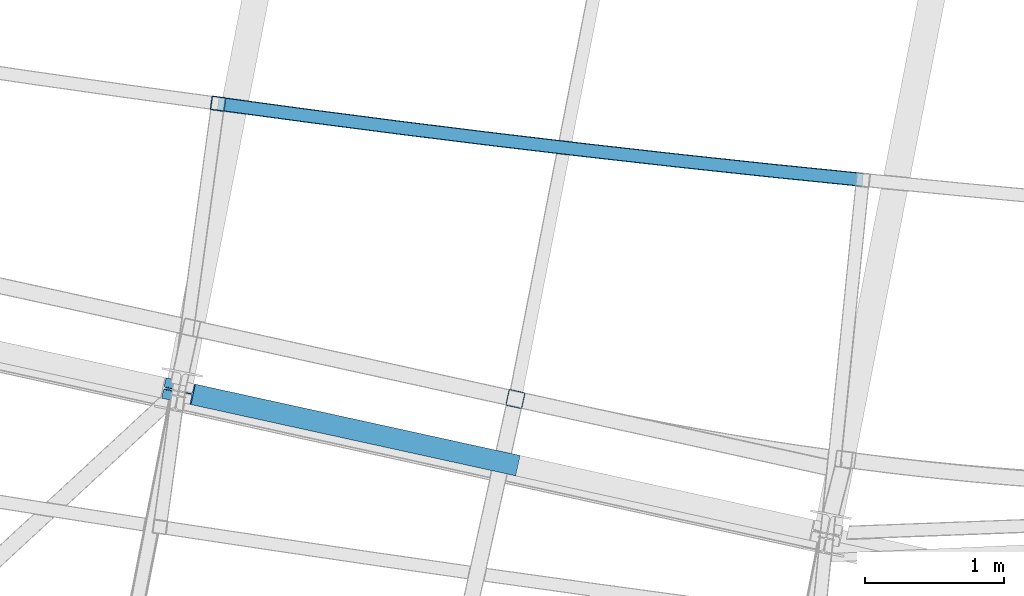
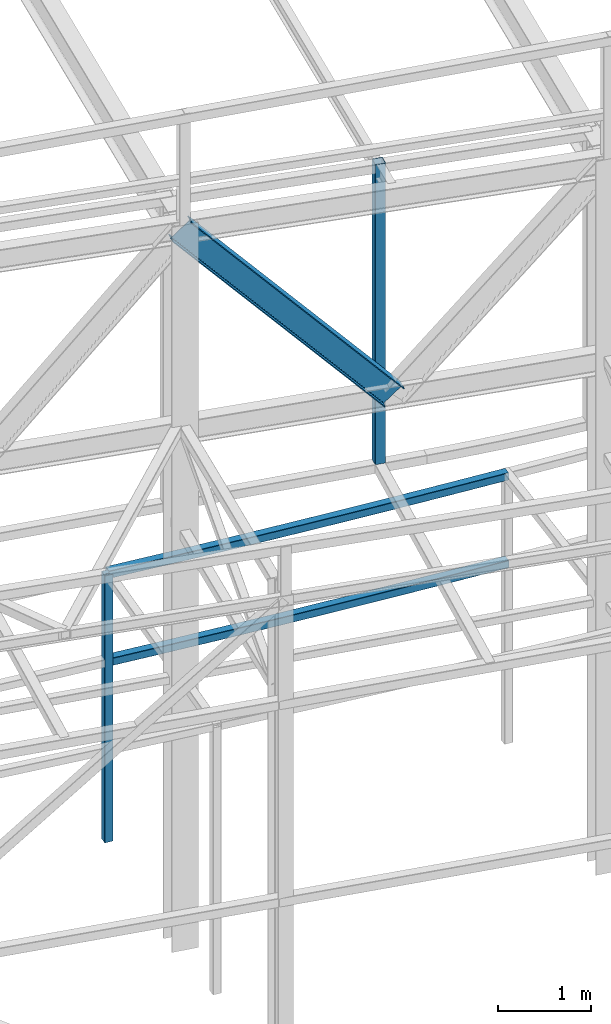
# One storey, part 49 of 215: 4 beams, 1 member, 5 elements without a shape of their own.
"""IFC2X3 building model written with IfcOpenShell, lengths in millimetres."""

import ifcopenshell
import ifcopenshell.guid

model = None  # the IFC model being written
_history = None  # IfcOwnerHistory: only IFC2X3 demands one
_inside = {}  # id of a spatial element -> (the spatial element, [elements in it])
_under = {}  # id of a project, library or spatial element -> (it, [spatial elements below it])
_declared = {}  # id of a project -> (the project, [libraries it declares])
_typed = {}  # id of a type object -> (the type object, [elements of that type])
_made_of = {}  # id of a material, layer set ... -> (it, [elements and type objects made of it])


def new_model(schema):
    """Start an empty IFC model of exactly this schema.

    Asked for "IFC4X3", IfcOpenShell would pick the latest addendum, in which some entities
    have other attributes; the version numbers below select the first issue.
    IFC2X3 requires an IfcOwnerHistory on every rooted entity: one is made here for all.
    """
    global model, _history
    if schema == "IFC4X3":
        model = ifcopenshell.file(schema_version=(4, 3, 0, 0))
    else:
        model = ifcopenshell.file(schema=schema)
    _inside.clear()
    _under.clear()
    _declared.clear()
    _typed.clear()
    _made_of.clear()
    _history = None
    if model.schema == "IFC2X3":
        org = make("IfcOrganization", Name="unknown")
        user = make(
            "IfcPersonAndOrganization",
            ThePerson=make("IfcPerson", FamilyName="unknown"),
            TheOrganization=org,
        )
        app = make(
            "IfcApplication",
            ApplicationDeveloper=org,
            Version="unknown",
            ApplicationFullName="unknown",
            ApplicationIdentifier="unknown",
        )
        _history = make(
            "IfcOwnerHistory",
            OwningUser=user,
            OwningApplication=app,
            ChangeAction="ADDED",
            CreationDate=0,
        )
    return model


def make(cls, **values):
    """One entity of the class cls with the attributes given. An attribute that is None is left unset."""
    return model.create_entity(
        cls, **{name: value for name, value in values.items() if value is not None}
    )


def entity(cls, *values):
    """Any entity or typed value of the class cls, its attributes in the order of the schema. None: left unset."""
    e = model.create_entity(cls)
    for i, value in enumerate(values):
        if value is not None:
            e[i] = value
    return e


def rooted(cls, **values):
    """An entity with a GlobalId (a new one), such as an element, a storey or a relation."""
    return make(cls, GlobalId=ifcopenshell.guid.new(), OwnerHistory=_history, **values)


def si_unit(unit_type, name, prefix=None):
    """IfcSIUnit, for example si_unit("LENGTHUNIT", "METRE", prefix="MILLI")."""
    return make("IfcSIUnit", UnitType=unit_type, Prefix=prefix, Name=name)


def assignment(units):
    """IfcUnitAssignment: the units of a project."""
    return None if units is None else make("IfcUnitAssignment", Units=units)


def point(xyz):
    """IfcCartesianPoint."""
    return None if xyz is None else make("IfcCartesianPoint", Coordinates=xyz)


def direction(xyz):
    """IfcDirection."""
    return None if xyz is None else make("IfcDirection", DirectionRatios=xyz)


def frame(location, z_axis=None, x_axis=None):
    """IfcAxis2Placement3D, a coordinate frame: its origin and axes. An axis left out is left unset."""
    return make(
        "IfcAxis2Placement3D",
        Location=point(location),
        Axis=direction(z_axis),
        RefDirection=direction(x_axis),
    )


def frame_2d(location, x_axis=None):
    """IfcAxis2Placement2D, a coordinate frame in the plane: its origin and x axis."""
    return make(
        "IfcAxis2Placement2D", Location=point(location), RefDirection=direction(x_axis)
    )


def origin_with_axes():
    """The frame at (0, 0, 0) with the z axis (0, 0, 1) and the x axis (1, 0, 0) written out."""
    return frame((0.0, 0.0, 0.0), z_axis=(0.0, 0.0, 1.0), x_axis=(1.0, 0.0, 0.0))


def origin_2d_with_axis():
    """The frame at (0, 0) in the plane with the x axis (1, 0) written out."""
    return frame_2d((0.0, 0.0), x_axis=(1.0, 0.0))


def place(relative_to, where):
    """IfcLocalPlacement: puts the frame where relative to a parent placement (None: the world)."""
    return make(
        "IfcLocalPlacement", PlacementRelTo=relative_to, RelativePlacement=where
    )


def context(
    kind, dimensions, precision=None, world=None, true_north=None, identifier=None
):
    """IfcGeometricRepresentationContext, for example the 3D "Model" context."""
    return make(
        "IfcGeometricRepresentationContext",
        ContextIdentifier=identifier,
        ContextType=kind,
        CoordinateSpaceDimension=dimensions,
        Precision=precision,
        WorldCoordinateSystem=world,
        TrueNorth=true_north,
    )


def subcontext(parent, identifier, kind, view, scale=None):
    """IfcGeometricRepresentationSubContext, for example "Body" below "Model"."""
    return make(
        "IfcGeometricRepresentationSubContext",
        ContextIdentifier=identifier,
        ContextType=kind,
        ParentContext=parent,
        TargetScale=scale,
        TargetView=view,
    )


def project(units=None, contexts=None):
    """IfcProject with its units and contexts."""
    return rooted(
        "IfcProject",
        Name="project",
        RepresentationContexts=contexts,
        UnitsInContext=assignment(units),
    )


def spatial(cls, under=None, at=None, **own):
    """A site, building, storey or space (cls), placed at a placement, below another one or the project."""
    s = rooted(cls, ObjectPlacement=at, **own)
    if under is not None:
        _under.setdefault(under.id(), (under, []))[1].append(s)
    return s


def profile(cls, at=None, kind="AREA", **sizes):
    """A parametric profile (cls). Its sizes go by their IFC names, for example OverallWidth=200.0."""
    return make(cls, ProfileType=kind, Position=at, **sizes)


def hollow_rectangle(**sizes):
    """IfcRectangleHollowProfileDef."""
    return profile("IfcRectangleHollowProfileDef", **sizes)


def i_section(**sizes):
    """IfcIShapeProfileDef."""
    return profile("IfcIShapeProfileDef", **sizes)


def extrude(swept, where, along, depth):
    """IfcExtrudedAreaSolid: the profile swept, set in the frame where, extruded along a direction by depth."""
    return make(
        "IfcExtrudedAreaSolid",
        SweptArea=swept,
        Position=where,
        ExtrudedDirection=direction(along),
        Depth=depth,
    )


def shape(context_of_items, identifier, shape_type, items):
    """IfcShapeRepresentation: the items that make up one representation, for example the "Body"."""
    return make(
        "IfcShapeRepresentation",
        ContextOfItems=context_of_items,
        RepresentationIdentifier=identifier,
        RepresentationType=shape_type,
        Items=items,
    )


def material(Name=None, Category=None):
    """IfcMaterial."""
    return make("IfcMaterial", Name=Name, Category=Category)


def made_of(thing, what):
    """Note that an element or type object is made of a material, layer set ...; save() writes the relation."""
    if what is not None:
        _made_of.setdefault(what.id(), (what, []))[1].append(thing)
    return thing


def type_object(cls, material=None, **own):
    """A type object (cls), such as IfcWallType, which elements share."""
    return made_of(rooted(cls, **own), material)


def element(
    cls,
    number,
    at=None,
    inside=None,
    cuts=None,
    type_object=None,
    material=None,
    context=None,
    identifier="Body",
    shape_type=None,
    held_by="IfcProductDefinitionShape",
    body=None,
    shapes=None,
    **own,
):
    """One element of the class cls, such as IfcWall. Its Tag is "e" and its number.

    at: its placement. inside: the storey or other place that contains it. cuts: it is an
    opening in that element (IfcRelVoidsElement). A single representation is given by context,
    identifier, shape_type and body (its items); several are given by shapes. held_by: the class
    of the entity that holds the representations. save() writes the other relations.
    """
    e = rooted(cls, Tag="e%d" % number, ObjectPlacement=at, **own)
    if body is not None:
        shapes = [shape(context, identifier, shape_type, body)]
    if shapes is not None:
        e.Representation = make(held_by, Representations=shapes)
    if inside is not None:
        _inside.setdefault(inside.id(), (inside, []))[1].append(e)
    if cuts is not None:
        rooted(
            "IfcRelVoidsElement", RelatingBuildingElement=cuts, RelatedOpeningElement=e
        )
    if type_object is not None:
        _typed.setdefault(type_object.id(), (type_object, []))[1].append(e)
    return made_of(e, material)


def aggregate(whole, parts):
    """IfcRelAggregates: a whole, such as a stair, and the parts it consists of."""
    return rooted("IfcRelAggregates", RelatingObject=whole, RelatedObjects=parts)


def save(model, path):
    """Write the relations noted so far, then the file.

    IfcRelAggregates (storeys below a building ...), IfcRelContainedInSpatialStructure (elements
    in a storey), IfcRelDefinesByType, IfcRelAssociatesMaterial and IfcRelDeclares: one each for
    every whole, place, type object, material and project.
    """
    for whole, parts in _under.values():
        aggregate(whole, parts)
    for where, things in _inside.values():
        rooted(
            "IfcRelContainedInSpatialStructure",
            RelatedElements=things,
            RelatingStructure=where,
        )
    for kind, things in _typed.values():
        rooted("IfcRelDefinesByType", RelatedObjects=things, RelatingType=kind)
    for what, things in _made_of.values():
        rooted("IfcRelAssociatesMaterial", RelatedObjects=things, RelatingMaterial=what)
    for by, libraries in _declared.values():
        rooted("IfcRelDeclares", RelatingContext=by, RelatedDefinitions=libraries)
    model.write(path)


model = new_model("IFC2X3")

# Units and contexts
model_context = context("Model", 3, precision=1e-05, world=origin_with_axes())
body_context = subcontext(model_context, "Body", "Model", "MODEL_VIEW")
ifc_project = project(units=[si_unit("LENGTHUNIT", "METRE", prefix="MILLI"), si_unit("AREAUNIT", "SQUARE_METRE"), si_unit("VOLUMEUNIT", "CUBIC_METRE"), si_unit("MASSUNIT", "GRAM", prefix="KILO"), si_unit("TIMEUNIT", "SECOND"), si_unit("PLANEANGLEUNIT", "RADIAN"), si_unit("SOLIDANGLEUNIT", "STERADIAN"), si_unit("THERMODYNAMICTEMPERATUREUNIT", "DEGREE_CELSIUS"), si_unit("LUMINOUSINTENSITYUNIT", "LUMEN")], contexts=[model_context])

# Site, building, storey
site_placement = place(None, origin_with_axes())
site = spatial("IfcSite", under=ifc_project, at=site_placement, CompositionType="ELEMENT")
building_placement = place(site_placement, origin_with_axes())
building = spatial("IfcBuilding", under=site, at=building_placement, Name="Undefined", CompositionType="ELEMENT")
storey_placement = place(building_placement, origin_with_axes())
storey = spatial("IfcBuildingStorey", under=building, at=storey_placement, Name="Undefined", CompositionType="ELEMENT", Elevation=0.0)

# Assembly, beam
assembly_1_placement = place(storey_placement, origin_with_axes())
assembly_1 = element("IfcElementAssembly", 1, at=assembly_1_placement, inside=storey, Name="Steel Assembly", AssemblyPlace="NOTDEFINED", PredefinedType="RIGID_FRAME")
ifc_material = material(Name="STEEL/S275JR")
beam_type_1 = type_object("IfcBeamType", PredefinedType="NOTDEFINED")
beam_1_placement = place(assembly_1_placement, frame((69877.4358574344, 6869.17982284336, 5610.00000147687), z_axis=(0.117385962964599, 0.993086368700565, 0.0), x_axis=(0.993086368700564, -0.117385962964606, 0.0)))
beam_1 = element("IfcBeam", 2, at=beam_1_placement, type_object=beam_type_1, material=ifc_material, Name="POUTRE", context=body_context, shape_type="SweptSolid", body=[
    entity("IfcRevolvedAreaSolid", entity("IfcRectangleHollowProfileDef", "AREA", None, entity("IfcAxis2Placement2D", entity("IfcCartesianPoint", [0.0, 0.0]), entity("IfcDirection", [1.0, 0.0])), 100.0, 100.0, 4.0, 4.0, 8.0), entity("IfcAxis2Placement3D", entity("IfcCartesianPoint", [4672.50445759871, 0.0, 6.48440253936221e-14]), entity("IfcDirection", [-0.999810465563468, 0.0, -0.019468768573328]), entity("IfcDirection", [-6.93889390390723e-18, -1.0, -3.46944695195361e-18])), entity("IfcAxis1Placement", entity("IfcCartesianPoint", [0.0, 120000.0, 0.0]), entity("IfcDirection", [-1.0, 0.0, 0.0])), 0.0389399973345591),
])
aggregate(assembly_1, [beam_1])

assembly_2_placement = place(storey_placement, origin_with_axes())
assembly_2 = element("IfcElementAssembly", 3, at=assembly_2_placement, inside=storey, Name="Steel Assembly", AssemblyPlace="NOTDEFINED", PredefinedType="RIGID_FRAME")
beam_2_placement = place(assembly_2_placement, frame((69877.4358571639, 6869.17982280737, 6760.00000147687), z_axis=(0.117385962964599, 0.993086368700565, 0.0), x_axis=(0.993086368700564, -0.117385962964606, 0.0)))
beam_2 = element("IfcBeam", 4, at=beam_2_placement, type_object=beam_type_1, material=ifc_material, Name="POUTRE", context=body_context, shape_type="SweptSolid", body=[
    entity("IfcRevolvedAreaSolid", entity("IfcRectangleHollowProfileDef", "AREA", None, entity("IfcAxis2Placement2D", entity("IfcCartesianPoint", [0.0, 0.0]), entity("IfcDirection", [1.0, 0.0])), 100.0, 100.0, 4.0, 4.0, 8.0), entity("IfcAxis2Placement3D", entity("IfcCartesianPoint", [4672.50445759871, 0.0, 6.48440253936221e-14]), entity("IfcDirection", [-0.999810465563468, 0.0, -0.019468768573328]), entity("IfcDirection", [-6.93889390390723e-18, -1.0, -3.46944695195361e-18])), entity("IfcAxis1Placement", entity("IfcCartesianPoint", [0.0, 120000.0, 0.0]), entity("IfcDirection", [-1.0, 0.0, 0.0])), 0.0389399973340144),
])
aggregate(assembly_2, [beam_2])

assembly_3_placement = place(storey_placement, origin_with_axes())
assembly_3 = element("IfcElementAssembly", 5, at=assembly_3_placement, inside=storey, Name="Steel Assembly", AssemblyPlace="NOTDEFINED", PredefinedType="RIGID_FRAME")
beam_3_placement = place(assembly_3_placement, frame((69877.4358571639, 6869.17982280737, 6760.00000147687), z_axis=(-0.990749114285665, 0.135706273039128, 0.0), x_axis=(0.0, 0.0, -1.0)))
beam_3 = element("IfcBeam", 6, at=beam_3_placement, type_object=beam_type_1, material=ifc_material, Name="MONTANT", context=body_context, shape_type="SweptSolid", body=[
    extrude(hollow_rectangle(XDim=100.0, YDim=100.0, WallThickness=4.0, InnerFilletRadius=4.0, OuterFilletRadius=8.0, at=origin_2d_with_axis()), frame((3499.99999998675, 0.0, 0.0), z_axis=(-1.0, 0.0, 0.0), x_axis=(-6.93889390390723e-18, -1.0, -3.46944695195361e-18)), (0.0, 0.0, 1.0), 3500.0),
])
aggregate(assembly_3, [beam_3])

assembly_4_placement = place(storey_placement, origin_with_axes())
assembly_4 = element("IfcElementAssembly", 7, at=assembly_4_placement, inside=storey, Name="Steel Assembly", AssemblyPlace="NOTDEFINED", PredefinedType="RIGID_FRAME")
beam_type_2 = type_object("IfcBeamType", PredefinedType="NOTDEFINED")
beam_4_placement = place(assembly_4_placement, frame((72018.0659072373, 4743.39754167238, 12697.9286577163), z_axis=(-0.214538758981639, -0.97671547591641, 0.0), x_axis=(0.0, 0.0, -1.0)))
beam_4 = element("IfcBeam", 8, at=beam_4_placement, type_object=beam_type_2, material=ifc_material, Name="LISSE", context=body_context, shape_type="SweptSolid", body=[
    extrude(hollow_rectangle(XDim=120.0, YDim=120.0, WallThickness=5.0, InnerFilletRadius=5.0, OuterFilletRadius=10.0, at=origin_2d_with_axis()), frame((3931.92784965705, -1.30096579487745e-20, 3.63797880739663e-12), z_axis=(-1.0, 0.0, 0.0), x_axis=(-6.93889390390723e-18, -1.0, -3.46944695195361e-18)), (0.0, 0.0, 1.0), 3931.9),
])
aggregate(assembly_4, [beam_4])

# Assembly, member
assembly_5_placement = place(storey_placement, origin_with_axes())
assembly_5 = element("IfcElementAssembly", 9, at=assembly_5_placement, inside=storey, Name="Steel Assembly", AssemblyPlace="NOTDEFINED", PredefinedType="RIGID_FRAME")
member_type = type_object("IfcMemberType", Name="IPE300", PredefinedType="NOTDEFINED")
member_placement = place(assembly_5_placement, frame((69589.4100365749, 4800.78135840551, 12624.4105324029), z_axis=(-0.728285262247656, 0.15988787505437, -0.666360596226594), x_axis=(0.650867589993082, -0.142855957998482, -0.745629636992075)))
member = element("IfcMember", 10, at=member_placement, type_object=member_type, material=ifc_material, Name="POUTRE", ObjectType="IPE300", context=body_context, shape_type="SweptSolid", body=[
    extrude(i_section(OverallWidth=150.0, OverallDepth=300.0, WebThickness=7.099999905, FlangeThickness=10.69999981, FilletRadius=15.0, at=origin_2d_with_axis()), frame((3591.55064219213, -1.4099811166131e-13, -7.67469983589032e-12), z_axis=(-1.0, 0.0, 0.0), x_axis=(-6.93889390390723e-18, -1.0, -3.46944695195361e-18)), (0.0, 0.0, 1.0), 3591.6),
])
aggregate(assembly_5, [member])

save(model, "model.ifc")
